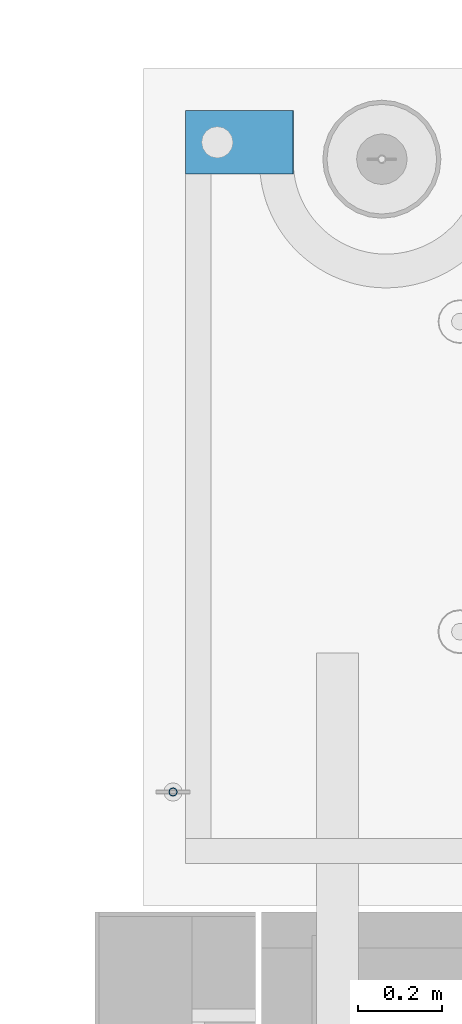
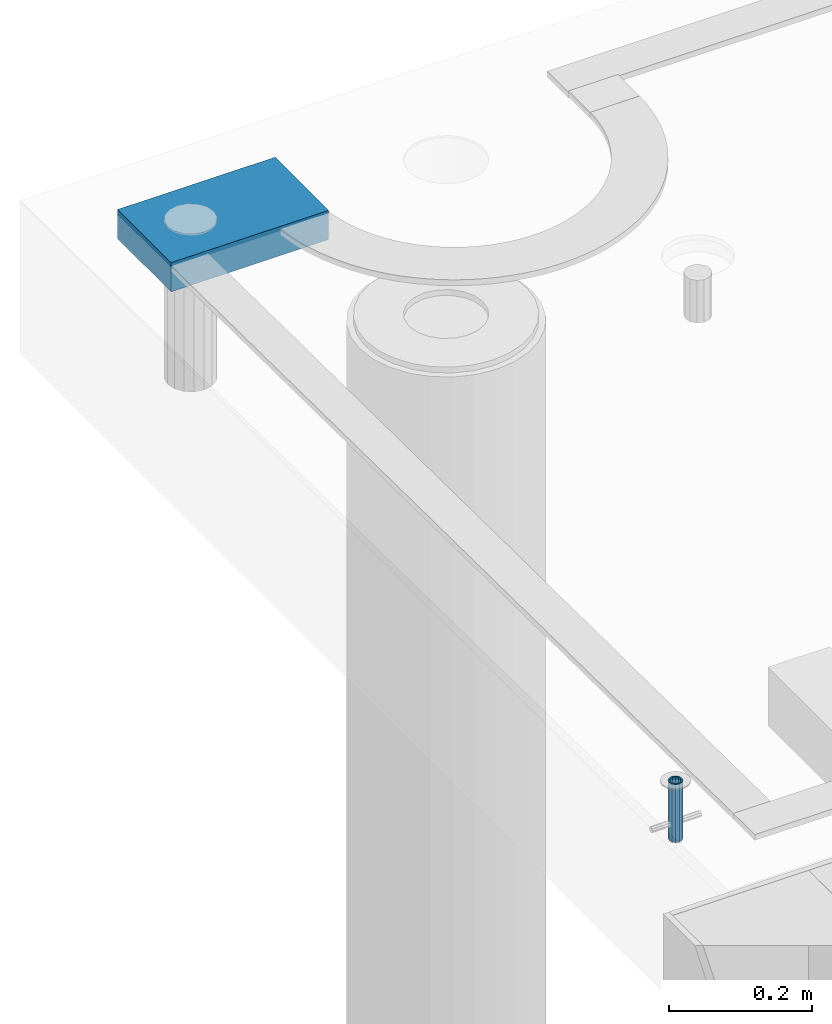
# One storey, part 147 of 334: 2 beams, 2 elements without a shape of their own.
"""IFC2X3 building model written with IfcOpenShell, lengths in millimetres."""

import ifcopenshell
import ifcopenshell.guid

model = None  # the IFC model being written
_history = None  # IfcOwnerHistory: only IFC2X3 demands one
_inside = {}  # id of a spatial element -> (the spatial element, [elements in it])
_under = {}  # id of a project, library or spatial element -> (it, [spatial elements below it])
_declared = {}  # id of a project -> (the project, [libraries it declares])
_typed = {}  # id of a type object -> (the type object, [elements of that type])
_made_of = {}  # id of a material, layer set ... -> (it, [elements and type objects made of it])


def new_model(schema):
    """Start an empty IFC model of exactly this schema.

    Asked for "IFC4X3", IfcOpenShell would pick the latest addendum, in which some entities
    have other attributes; the version numbers below select the first issue.
    IFC2X3 requires an IfcOwnerHistory on every rooted entity: one is made here for all.
    """
    global model, _history
    if schema == "IFC4X3":
        model = ifcopenshell.file(schema_version=(4, 3, 0, 0))
    else:
        model = ifcopenshell.file(schema=schema)
    _inside.clear()
    _under.clear()
    _declared.clear()
    _typed.clear()
    _made_of.clear()
    _history = None
    if model.schema == "IFC2X3":
        org = make("IfcOrganization", Name="unknown")
        user = make(
            "IfcPersonAndOrganization",
            ThePerson=make("IfcPerson", FamilyName="unknown"),
            TheOrganization=org,
        )
        app = make(
            "IfcApplication",
            ApplicationDeveloper=org,
            Version="unknown",
            ApplicationFullName="unknown",
            ApplicationIdentifier="unknown",
        )
        _history = make(
            "IfcOwnerHistory",
            OwningUser=user,
            OwningApplication=app,
            ChangeAction="ADDED",
            CreationDate=0,
        )
    return model


def make(cls, **values):
    """One entity of the class cls with the attributes given. An attribute that is None is left unset."""
    return model.create_entity(
        cls, **{name: value for name, value in values.items() if value is not None}
    )


def rooted(cls, **values):
    """An entity with a GlobalId (a new one), such as an element, a storey or a relation."""
    return make(cls, GlobalId=ifcopenshell.guid.new(), OwnerHistory=_history, **values)


def si_unit(unit_type, name, prefix=None):
    """IfcSIUnit, for example si_unit("LENGTHUNIT", "METRE", prefix="MILLI")."""
    return make("IfcSIUnit", UnitType=unit_type, Prefix=prefix, Name=name)


def assignment(units):
    """IfcUnitAssignment: the units of a project."""
    return None if units is None else make("IfcUnitAssignment", Units=units)


def point(xyz):
    """IfcCartesianPoint."""
    return None if xyz is None else make("IfcCartesianPoint", Coordinates=xyz)


def direction(xyz):
    """IfcDirection."""
    return None if xyz is None else make("IfcDirection", DirectionRatios=xyz)


def frame(location, z_axis=None, x_axis=None):
    """IfcAxis2Placement3D, a coordinate frame: its origin and axes. An axis left out is left unset."""
    return make(
        "IfcAxis2Placement3D",
        Location=point(location),
        Axis=direction(z_axis),
        RefDirection=direction(x_axis),
    )


def origin_with_axes():
    """The frame at (0, 0, 0) with the z axis (0, 0, 1) and the x axis (1, 0, 0) written out."""
    return frame((0.0, 0.0, 0.0), z_axis=(0.0, 0.0, 1.0), x_axis=(1.0, 0.0, 0.0))


def place(relative_to, where):
    """IfcLocalPlacement: puts the frame where relative to a parent placement (None: the world)."""
    return make(
        "IfcLocalPlacement", PlacementRelTo=relative_to, RelativePlacement=where
    )


def context(
    kind, dimensions, precision=None, world=None, true_north=None, identifier=None
):
    """IfcGeometricRepresentationContext, for example the 3D "Model" context."""
    return make(
        "IfcGeometricRepresentationContext",
        ContextIdentifier=identifier,
        ContextType=kind,
        CoordinateSpaceDimension=dimensions,
        Precision=precision,
        WorldCoordinateSystem=world,
        TrueNorth=true_north,
    )


def subcontext(parent, identifier, kind, view, scale=None):
    """IfcGeometricRepresentationSubContext, for example "Body" below "Model"."""
    return make(
        "IfcGeometricRepresentationSubContext",
        ContextIdentifier=identifier,
        ContextType=kind,
        ParentContext=parent,
        TargetScale=scale,
        TargetView=view,
    )


def project(units=None, contexts=None):
    """IfcProject with its units and contexts."""
    return rooted(
        "IfcProject",
        Name="project",
        RepresentationContexts=contexts,
        UnitsInContext=assignment(units),
    )


def spatial(cls, under=None, at=None, **own):
    """A site, building, storey or space (cls), placed at a placement, below another one or the project."""
    s = rooted(cls, ObjectPlacement=at, **own)
    if under is not None:
        _under.setdefault(under.id(), (under, []))[1].append(s)
    return s


def faces_of(points, faces, orient=None, outer=None):
    """IfcFace entities. A face is a list of loops; a loop is a list of indices into points, from 0.

    orient and outer hold one flag for each loop. By default every Orientation is true, the
    first loop of a face is its IfcFaceOuterBound and the others are IfcFaceBound.
    """
    made = []
    for i, loops in enumerate(faces):
        bounds = []
        for j, loop in enumerate(loops):
            is_outer = j == 0 if outer is None else outer[i][j]
            bounds.append(
                make(
                    "IfcFaceOuterBound" if is_outer else "IfcFaceBound",
                    Bound=make("IfcPolyLoop", Polygon=[points[k] for k in loop]),
                    Orientation=True if orient is None else orient[i][j],
                )
            )
        made.append(make("IfcFace", Bounds=bounds))
    return made


def faceted_brep(points, faces, orient=None, outer=None, voids=None):
    """IfcFacetedBrep: a solid bounded by flat faces; with voids (closed shells), ...WithVoids."""
    shared = [point(p) for p in points]
    hull = make("IfcClosedShell", CfsFaces=faces_of(shared, faces, orient, outer))
    if voids is None:
        return make("IfcFacetedBrep", Outer=hull)
    return make(
        "IfcFacetedBrepWithVoids",
        Outer=hull,
        Voids=[
            make(cls, CfsFaces=faces_of(shared, fs, o, b)) for cls, fs, o, b in voids
        ],
    )


def shape(context_of_items, identifier, shape_type, items):
    """IfcShapeRepresentation: the items that make up one representation, for example the "Body"."""
    return make(
        "IfcShapeRepresentation",
        ContextOfItems=context_of_items,
        RepresentationIdentifier=identifier,
        RepresentationType=shape_type,
        Items=items,
    )


def material(Name=None, Category=None):
    """IfcMaterial."""
    return make("IfcMaterial", Name=Name, Category=Category)


def made_of(thing, what):
    """Note that an element or type object is made of a material, layer set ...; save() writes the relation."""
    if what is not None:
        _made_of.setdefault(what.id(), (what, []))[1].append(thing)
    return thing


def type_object(cls, material=None, **own):
    """A type object (cls), such as IfcWallType, which elements share."""
    return made_of(rooted(cls, **own), material)


def element(
    cls,
    number,
    at=None,
    inside=None,
    cuts=None,
    type_object=None,
    material=None,
    context=None,
    identifier="Body",
    shape_type=None,
    held_by="IfcProductDefinitionShape",
    body=None,
    shapes=None,
    **own,
):
    """One element of the class cls, such as IfcWall. Its Tag is "e" and its number.

    at: its placement. inside: the storey or other place that contains it. cuts: it is an
    opening in that element (IfcRelVoidsElement). A single representation is given by context,
    identifier, shape_type and body (its items); several are given by shapes. held_by: the class
    of the entity that holds the representations. save() writes the other relations.
    """
    e = rooted(cls, Tag="e%d" % number, ObjectPlacement=at, **own)
    if body is not None:
        shapes = [shape(context, identifier, shape_type, body)]
    if shapes is not None:
        e.Representation = make(held_by, Representations=shapes)
    if inside is not None:
        _inside.setdefault(inside.id(), (inside, []))[1].append(e)
    if cuts is not None:
        rooted(
            "IfcRelVoidsElement", RelatingBuildingElement=cuts, RelatedOpeningElement=e
        )
    if type_object is not None:
        _typed.setdefault(type_object.id(), (type_object, []))[1].append(e)
    return made_of(e, material)


def aggregate(whole, parts):
    """IfcRelAggregates: a whole, such as a stair, and the parts it consists of."""
    return rooted("IfcRelAggregates", RelatingObject=whole, RelatedObjects=parts)


def save(model, path):
    """Write the relations noted so far, then the file.

    IfcRelAggregates (storeys below a building ...), IfcRelContainedInSpatialStructure (elements
    in a storey), IfcRelDefinesByType, IfcRelAssociatesMaterial and IfcRelDeclares: one each for
    every whole, place, type object, material and project.
    """
    for whole, parts in _under.values():
        aggregate(whole, parts)
    for where, things in _inside.values():
        rooted(
            "IfcRelContainedInSpatialStructure",
            RelatedElements=things,
            RelatingStructure=where,
        )
    for kind, things in _typed.values():
        rooted("IfcRelDefinesByType", RelatedObjects=things, RelatingType=kind)
    for what, things in _made_of.values():
        rooted("IfcRelAssociatesMaterial", RelatedObjects=things, RelatingMaterial=what)
    for by, libraries in _declared.values():
        rooted("IfcRelDeclares", RelatingContext=by, RelatedDefinitions=libraries)
    model.write(path)


model = new_model("IFC2X3")

# Units and contexts
model_context = context("Model", 3, precision=1e-05, world=origin_with_axes())
body_context = subcontext(model_context, "Body", "Model", "MODEL_VIEW")
ifc_project = project(units=[si_unit("LENGTHUNIT", "METRE", prefix="MILLI"), si_unit("AREAUNIT", "SQUARE_METRE"), si_unit("VOLUMEUNIT", "CUBIC_METRE"), si_unit("MASSUNIT", "GRAM", prefix="KILO"), si_unit("TIMEUNIT", "SECOND"), si_unit("PLANEANGLEUNIT", "RADIAN"), si_unit("SOLIDANGLEUNIT", "STERADIAN"), si_unit("THERMODYNAMICTEMPERATUREUNIT", "DEGREE_CELSIUS"), si_unit("LUMINOUSINTENSITYUNIT", "LUMEN")], contexts=[model_context])

# Site, building, storey
site_placement = place(None, origin_with_axes())
site = spatial("IfcSite", under=ifc_project, at=site_placement, CompositionType="ELEMENT")
building_placement = place(site_placement, origin_with_axes())
building = spatial("IfcBuilding", under=site, at=building_placement, CompositionType="ELEMENT")
storey_placement = place(building_placement, origin_with_axes())
storey = spatial("IfcBuildingStorey", under=building, at=storey_placement, Name="3", CompositionType="ELEMENT", Elevation=0.0)

# Assemblies, beams
assembly_1_placement = place(storey_placement, origin_with_axes())
assembly_1 = element("IfcElementAssembly", 1, at=assembly_1_placement, inside=storey, AssemblyPlace="NOTDEFINED", PredefinedType="REINFORCEMENT_UNIT")
ifc_material_1 = material(Name="CONCRETE/Concrete_Undefined")
beam_type_1 = type_object("IfcBeamType", PredefinedType="NOTDEFINED")
beam_1_placement = place(assembly_1_placement, frame((7834.97852488622, 22709.9981419457, 90691.8130006467), z_axis=(-0.000811736999627788, 6.99999872856177e-09, 0.999999670541467), x_axis=(0.99999967050638, -8.37699998998561e-06, 0.000811736999618736)))
beam_1 = element("IfcBeam", 2, at=beam_1_placement, type_object=beam_type_1, material=ifc_material_1, context=body_context, shape_type="Brep", body=[
    faceted_brep([(0.0, 75.0, -25.0), (1.81898940354586e-12, 75.0, 25.0), (254.995831308013, 74.9999999999964, 24.9999999999709), (254.995831308012, 74.9999999999964, -25.0000000000146), (1.81898940354586e-12, -75.0000000000009, 25.0), (254.995831308014, -75.0000000000036, 24.9999999999854), (0.0, -75.0, -25.0), (254.995831308011, -75.0000000000036, -25.0000000000146)], [[[0, 1, 2, 3]], [[1, 4, 5, 2]], [[4, 6, 7, 5]], [[6, 0, 3, 7]], [[5, 7, 3, 2]], [[6, 4, 1, 0]]]),
])
assembly_2_placement = place(assembly_1_placement, origin_with_axes())
assembly_2 = element("IfcElementAssembly", 3, at=assembly_2_placement, Name="Steel Assembly", AssemblyPlace="NOTDEFINED", PredefinedType="RIGID_FRAME")
aggregate(assembly_1, [beam_1, assembly_2])
ifc_material_2 = material(Name="STEEL/1.4301")
beam_type_2 = type_object("IfcBeamType", PredefinedType="NOTDEFINED")
beam_2_placement = place(assembly_2_placement, frame((7804.99906039055, 21170.0168887753, 90730.9999983246), z_axis=(-1.43919999976435e-05, -0.999999999896435, 0.0), x_axis=(0.0, 0.0, -1.0)))
beam_2 = element("IfcBeam", 4, at=beam_2_placement, type_object=beam_type_2, material=ifc_material_2, context=body_context, shape_type="Brep", body=[
    faceted_brep([(0.0, -8.0, 0.0), (0.0, -6.92820323027263, 4.0), (100.000000000029, -6.92820323027263, 4.0), (100.000000000029, -7.99999999999636, 0.0), (0.0, -4.0, 6.92820323027627), (100.000000000029, -4.0, 6.92820323027536), (0.0, 0.0, 8.0), (100.000000000029, 3.63797880709171e-12, 8.0), (0.0, 4.0, 6.92820323027627), (100.000000000029, 4.0, 6.92820323027536), (0.0, 6.92820323027263, 4.0), (100.000000000029, 6.92820323027627, 3.99999999999909), (0.0, 8.0, 0.0), (100.000000000029, 8.0, 0.0), (0.0, 6.92820323027263, -4.0), (100.000000000029, 6.92820323027627, -4.00000000000091), (0.0, 4.0, -6.92820323027627), (100.000000000029, 4.00000000000364, -6.92820323027536), (0.0, 0.0, -8.0), (100.000000000029, 3.63797880709171e-12, -8.00000000000091), (0.0, -4.0, -6.92820323027627), (100.000000000029, -3.99999999999636, -6.92820323027627), (0.0, -6.92820323027263, -4.0), (100.000000000029, -6.92820323027263, -4.0), (0.0, -10.4999999999927, -1.45519152283669e-11), (0.0, -9.09326673972828, -5.25000000001455), (100.000000000262, -9.09326673972828, -5.25000000001455), (100.000000000262, -10.4999999999927, -1.45519152283669e-11), (0.0, -5.24999999998545, -9.09326673974283), (100.000000000262, -5.24999999998545, -9.09326673974283), (0.0, 7.27595761418343e-12, -10.5), (100.000000000262, 7.27595761418343e-12, -10.5), (0.0, 5.25000000001455, -9.09326673975738), (100.000000000262, 5.25000000001455, -9.09326673975738), (0.0, 9.09326673975011, -5.25000000001455), (100.000000000262, 9.09326673975011, -5.25000000001455), (0.0, 10.5000000000073, -1.45519152283669e-11), (100.000000000262, 10.5000000000073, -1.45519152283669e-11), (0.0, 9.09326673975011, 5.25), (100.000000000262, 9.09326673975011, 5.25), (0.0, 5.25000000000728, 9.09326673972828), (100.000000000262, 5.25000000000728, 9.09326673972828), (0.0, 1.45519152283669e-11, 10.4999999999854), (100.000000000262, 1.45519152283669e-11, 10.4999999999854), (0.0, -5.24999999999272, 9.09326673972828), (100.000000000262, -5.24999999999272, 9.09326673972828), (0.0, -9.09326673972828, 5.24999999998545), (100.000000000262, -9.09326673972828, 5.24999999998545)], [[[0, 1, 2, 3]], [[1, 4, 5, 2]], [[4, 6, 7, 5]], [[6, 8, 9, 7]], [[8, 10, 11, 9]], [[10, 12, 13, 11]], [[12, 14, 15, 13]], [[14, 16, 17, 15]], [[16, 18, 19, 17]], [[18, 20, 21, 19]], [[20, 22, 23, 21]], [[22, 0, 3, 23]], [[24, 25, 26, 27]], [[25, 28, 29, 26]], [[28, 30, 31, 29]], [[30, 32, 33, 31]], [[32, 34, 35, 33]], [[34, 36, 37, 35]], [[36, 38, 39, 37]], [[38, 40, 41, 39]], [[40, 42, 43, 41]], [[42, 44, 45, 43]], [[44, 46, 47, 45]], [[46, 24, 27, 47]], [[29, 31, 33, 35, 37, 39, 41, 43, 45, 47, 27, 26], [5, 7, 9, 11, 13, 15, 17, 19, 21, 23, 3, 2]], [[46, 44, 42, 40, 38, 36, 34, 32, 30, 28, 25, 24], [22, 20, 18, 16, 14, 12, 10, 8, 6, 4, 1, 0]]]),
])
aggregate(assembly_2, [beam_2])

save(model, "model.ifc")
